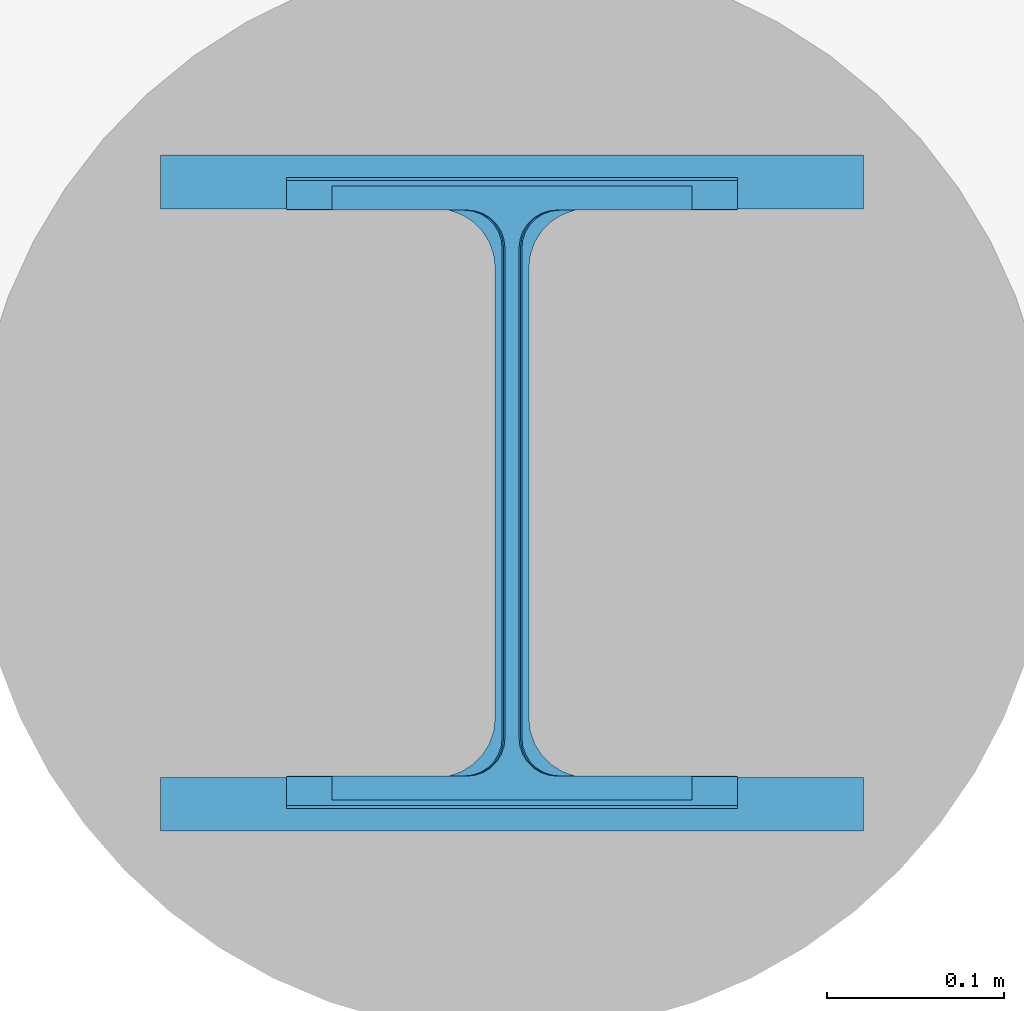
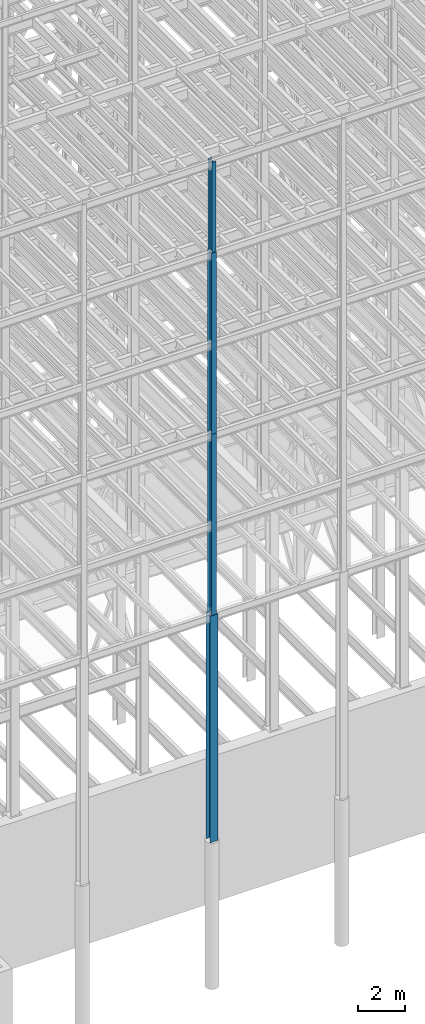
# One storey, part 30 of 150: 4 columns.
"""IFC2X3 building model written with IfcOpenShell, lengths in millimetres."""

from ifc_helpers import new_model, si_unit, frame, origin_with_axes, origin_2d_with_axis, place, context, subcontext, project, spatial, i_section, extrude, material, type_object, element, save


model = new_model("IFC2X3")

# Units and contexts
model_context = context("Model", 3, precision=1e-05, world=origin_with_axes())
body_context = subcontext(model_context, "Body", "Model", "MODEL_VIEW")
ifc_project = project(units=[si_unit("LENGTHUNIT", "METRE", prefix="MILLI"), si_unit("AREAUNIT", "SQUARE_METRE"), si_unit("VOLUMEUNIT", "CUBIC_METRE"), si_unit("MASSUNIT", "GRAM", prefix="KILO"), si_unit("TIMEUNIT", "SECOND"), si_unit("PLANEANGLEUNIT", "RADIAN"), si_unit("SOLIDANGLEUNIT", "STERADIAN"), si_unit("THERMODYNAMICTEMPERATUREUNIT", "DEGREE_CELSIUS"), si_unit("LUMINOUSINTENSITYUNIT", "LUMEN")], contexts=[model_context])

# Site, building, storey
site_placement = place(None, origin_with_axes())
site = spatial("IfcSite", under=ifc_project, at=site_placement, CompositionType="ELEMENT")
building_placement = place(site_placement, origin_with_axes())
building = spatial("IfcBuilding", under=site, at=building_placement, Name="Undefined", CompositionType="ELEMENT")
storey_placement = place(building_placement, origin_with_axes())
storey = spatial("IfcBuildingStorey", under=building, at=storey_placement, Name="Undefined", CompositionType="ELEMENT", Elevation=0.0)

# Columns
ifc_material = material(Name="STEEL/A992")
column_type_1 = type_object("IfcColumnType", Name="W14X43", PredefinedType="NOTDEFINED")
column_1_placement = place(storey_placement, frame((56591.2, 3454.4, 54483.0), z_axis=(0.0, 0.0, 1.0), x_axis=(1.0, 0.0, 0.0)))
element("IfcColumn", 1, at=column_1_placement, inside=storey, type_object=column_type_1, material=ifc_material, Name="COLUMN", ObjectType="W14X43", context=body_context, shape_type="SweptSolid", body=[
    extrude(i_section(OverallWidth=203.2, OverallDepth=346.075, WebThickness=7.9375, FlangeThickness=13.462, FilletRadius=21.4629, at=origin_2d_with_axis()), frame((0.0, 0.0, 4724.39999999999), z_axis=(0.0, 0.0, -1.0), x_axis=(-1.0, 0.0, 0.0)), (0.0, 0.0, 1.0), 4724.4),
])
column_type_2 = type_object("IfcColumnType", Name="W14X61", PredefinedType="NOTDEFINED")
column_2_placement = place(storey_placement, frame((56591.2, 3454.4, 45034.2), z_axis=(0.0, 0.0, 1.0), x_axis=(1.0, 0.0, 0.0)))
element("IfcColumn", 2, at=column_2_placement, inside=storey, type_object=column_type_2, material=ifc_material, Name="COLUMN", ObjectType="W14X61", context=body_context, shape_type="SweptSolid", body=[
    extrude(i_section(OverallWidth=254.0, OverallDepth=352.425, WebThickness=9.5249, FlangeThickness=16.383, FilletRadius=21.717, at=origin_2d_with_axis()), frame((0.0, 0.0, 9448.8), z_axis=(0.0, 0.0, -1.0), x_axis=(-1.0, 0.0, 0.0)), (0.0, 0.0, 1.0), 9448.8),
])
column_type_3 = type_object("IfcColumnType", Name="W14X68", PredefinedType="NOTDEFINED")
column_3_placement = place(storey_placement, frame((56591.2, 3454.4, 35585.4), z_axis=(0.0, 0.0, 1.0), x_axis=(1.0, 0.0, 0.0)))
element("IfcColumn", 3, at=column_3_placement, inside=storey, type_object=column_type_3, material=ifc_material, Name="COLUMN", ObjectType="W14X68", context=body_context, shape_type="SweptSolid", body=[
    extrude(i_section(OverallWidth=254.0, OverallDepth=355.6, WebThickness=11.1125, FlangeThickness=18.288, FilletRadius=21.3994, at=origin_2d_with_axis()), frame((0.0, 0.0, 9448.8), z_axis=(0.0, 0.0, -1.0), x_axis=(-1.0, 0.0, 0.0)), (0.0, 0.0, 1.0), 9448.8),
])
column_type_4 = type_object("IfcColumnType", Name="W14X159", PredefinedType="NOTDEFINED")
column_4_placement = place(storey_placement, frame((56591.2, 3454.4, 23774.4), z_axis=(0.0, 0.0, 1.0), x_axis=(1.0, 0.0, 0.0)))
element("IfcColumn", 4, at=column_4_placement, inside=storey, type_object=column_type_4, material=ifc_material, Name="COLUMN", ObjectType="W14X159", context=body_context, shape_type="SweptSolid", body=[
    extrude(i_section(OverallWidth=396.24, OverallDepth=381.0, WebThickness=19.0499, FlangeThickness=30.226, FilletRadius=33.2739, at=origin_2d_with_axis()), frame((0.0, 0.0, 11810.9988189), z_axis=(0.0, 0.0, -1.0), x_axis=(-1.0, 0.0, 0.0)), (0.0, 0.0, 1.0), 11810.9988189),
])

save(model, "model.ifc")
